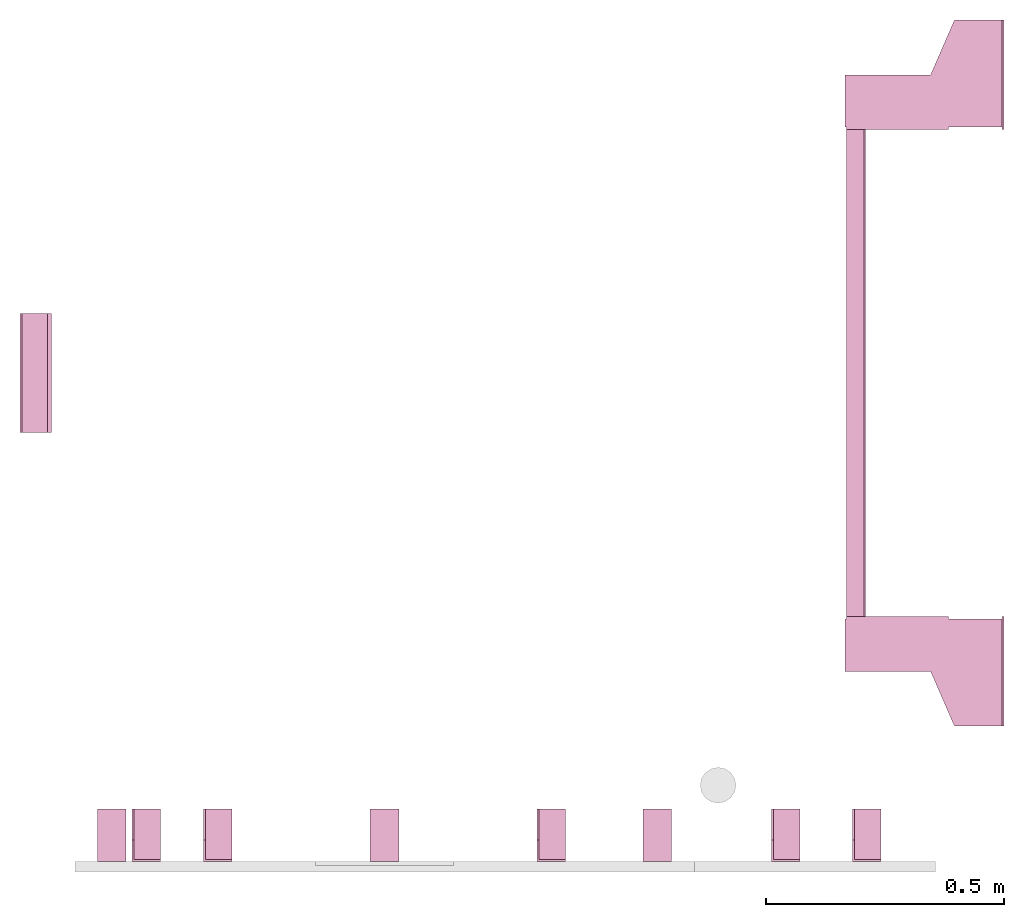
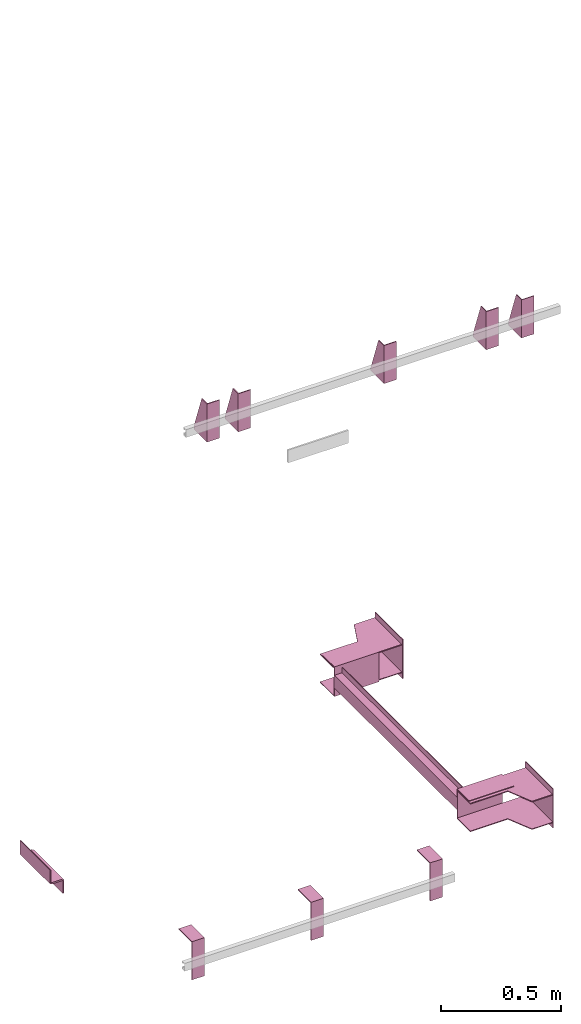
# One storey, part 4 of 4: 10 transport elements.
"""IFC4 building model written with IfcOpenShell, lengths in millimetres."""

from ifc_helpers import new_model, entity, si_unit, converted_unit, frame, origin_with_axes, place, context, subcontext, project, spatial, faceted_brep, element, save


model = new_model("IFC4")

# Units and contexts
context_of_model = context(None, 3, precision=0.01, world=origin_with_axes())
sub_context_1 = subcontext(context_of_model, None, None, "MODEL_VIEW")
sub_context_2 = subcontext(context_of_model, None, None, "MODEL_VIEW")
sub_context_3 = subcontext(context_of_model, None, None, "MODEL_VIEW")
sub_context_4 = subcontext(context_of_model, None, None, "MODEL_VIEW")
sub_context_5 = subcontext(context_of_model, None, None, "MODEL_VIEW")
sub_context_6 = subcontext(context_of_model, None, None, "MODEL_VIEW")
sub_context_7 = subcontext(context_of_model, None, None, "MODEL_VIEW")
sub_context_8 = subcontext(context_of_model, None, None, "MODEL_VIEW")
sub_context_9 = subcontext(context_of_model, None, None, "MODEL_VIEW")
sub_context_10 = subcontext(context_of_model, None, None, "MODEL_VIEW")
ifc_project = project(units=[converted_unit("PLANEANGLEUNIT", "degree", entity("IfcPlaneAngleMeasure", 0.017453292519943), si_unit("PLANEANGLEUNIT", "RADIAN"), dimensions=[0, 0, 0, 0, 0, 0, 0]), si_unit("LENGTHUNIT", "METRE", prefix="MILLI"), si_unit("MASSUNIT", "GRAM", prefix="KILO"), converted_unit("TIMEUNIT", "year", entity("IfcTimeMeasure", 31557600.0), si_unit("TIMEUNIT", "SECOND"), dimensions=[0, 0, 1, 0, 0, 0, 0]), si_unit("THERMODYNAMICTEMPERATUREUNIT", "DEGREE_CELSIUS"), si_unit("AREAUNIT", "SQUARE_METRE"), si_unit("FORCEUNIT", "NEWTON"), si_unit("VOLUMEUNIT", "CUBIC_METRE"), si_unit("PRESSUREUNIT", "PASCAL"), si_unit("SOLIDANGLEUNIT", "STERADIAN")], contexts=[context_of_model])

# Site, building, storey
site = spatial("IfcSite", under=ifc_project)
building = spatial("IfcBuilding", under=site, Name="Document")
placement = place(None, origin_with_axes())
storey_placement = place(placement, frame((0.0, 0.0, -17510.0), z_axis=(0.0, 0.0, 1.0), x_axis=(1.0, 0.0, 0.0)))
storey = spatial("IfcBuildingStorey", under=building, at=storey_placement, Name="P6", Elevation=-17510.0)

# Transport elements
transport_element_1_placement = place(storey_placement, frame((2065.0, 1025.0, -190.0), z_axis=(0.0, 0.0, 1.0), x_axis=(0.0, 1.0, 0.0)))
element("IfcTransportElement", 1, at=transport_element_1_placement, inside=storey, PredefinedType="ELEVATOR", context=sub_context_1, shape_type="Brep", body=[
    faceted_brep([(-611.0, 331.0, -72.5), (-514.0, 331.0, -72.5), (-514.0, 331.0, 72.5), (-611.0, 331.0, 72.5), (-611.0, 331.0, 75.5), (-511.0, 331.0, 75.5), (-511.0, 331.0, -75.5), (-611.0, 331.0, -75.5), (-511.0, 116.0, -75.5), (-511.0, 116.0, 75.5), (-611.0, 116.0, 75.5), (-611.0, 116.0, 72.5), (-514.0, 116.0, 72.5), (-514.0, 116.0, -72.5), (-611.0, 116.0, -72.5), (-611.0, 116.0, -75.5)], [[[0, 1, 2, 3, 4, 5, 6, 7]], [[8, 9, 10, 11, 12, 13, 14, 15]], [[15, 14, 0, 7]], [[13, 12, 2, 1]], [[5, 9, 8, 6]], [[11, 10, 4, 3]], [[6, 8, 15, 7]], [[14, 13, 1, 0]], [[2, 12, 11, 3]], [[10, 9, 5, 4]]]),
    faceted_brep([(-511.0, 291.0, -32.5), (-511.0, 294.0, -32.5), (-511.0, 294.0, -59.5), (-511.0, 291.0, -59.5), (511.0, 291.0, -32.5), (511.0, 291.0, -59.5), (511.0, 294.0, -59.5), (511.0, 294.0, -32.5)], [[[0, 1, 2, 3]], [[4, 5, 6, 7]], [[0, 3, 5, 4]], [[3, 2, 6, 5]], [[2, 1, 7, 6]], [[1, 0, 4, 7]]]),
    faceted_brep([(-511.0, 331.0, 32.5), (511.0, 331.0, 32.5), (511.0, 331.0, -32.5), (-511.0, 331.0, -32.5), (511.0, 328.0, -29.5), (511.0, 328.0, 29.5), (-511.0, 328.0, 29.5), (-511.0, 328.0, -29.5), (511.0, 291.0, -32.5), (511.0, 291.0, -29.5), (-511.0, 291.0, -29.5), (-511.0, 291.0, -32.5), (511.0, 291.0, 29.5), (511.0, 291.0, 32.5), (-511.0, 291.0, 32.5), (-511.0, 291.0, 29.5)], [[[0, 1, 2, 3]], [[4, 5, 6, 7]], [[8, 9, 10, 11]], [[12, 13, 14, 15]], [[11, 10, 7, 6, 15, 14, 0, 3]], [[2, 1, 13, 12, 5, 4, 9, 8]], [[2, 8, 11, 3]], [[10, 9, 4, 7]], [[14, 13, 1, 0]], [[5, 12, 15, 6]]]),
    faceted_brep([(511.0, 331.0, 75.5), (611.0, 331.0, 75.5), (611.0, 331.0, 72.5), (514.0, 331.0, 72.5), (514.0, 331.0, -72.5), (611.0, 331.0, -72.5), (611.0, 331.0, -75.5), (511.0, 331.0, -75.5), (511.0, 116.0, -75.5), (611.0, 116.0, -75.5), (611.0, 116.0, -72.5), (514.0, 116.0, -72.5), (514.0, 116.0, 72.5), (611.0, 116.0, 72.5), (611.0, 116.0, 75.5), (511.0, 116.0, 75.5)], [[[0, 1, 2, 3, 4, 5, 6, 7]], [[8, 9, 10, 11, 12, 13, 14, 15]], [[8, 15, 0, 7]], [[3, 12, 11, 4]], [[5, 10, 9, 6]], [[1, 14, 13, 2]], [[6, 9, 8, 7]], [[11, 10, 5, 4]], [[15, 14, 1, 0]], [[2, 13, 12, 3]]]),
    faceted_brep([(-511.0, 291.0, 59.5), (-511.0, 294.0, 59.5), (-511.0, 294.0, 32.5), (-511.0, 291.0, 32.5), (511.0, 291.0, 59.5), (511.0, 291.0, 32.5), (511.0, 294.0, 32.5), (511.0, 294.0, 59.5)], [[[0, 1, 2, 3]], [[4, 5, 6, 7]], [[0, 3, 5, 4]], [[3, 2, 6, 5]], [[2, 1, 7, 6]], [[1, 0, 4, 7]]]),
    faceted_brep([(516.0, 334.0, -68.5), (626.0, 334.0, -68.5), (626.0, 334.0, -72.5), (516.0, 334.0, -72.5), (741.0, 4.0, -72.5), (741.0, 4.0, -68.5), (516.0, 4.0, -68.5), (516.0, 4.0, -72.5), (626.0, 154.0, -68.5), (741.0, 104.0, -68.5), (741.0, 104.0, -72.5), (626.0, 154.0, -72.5)], [[[0, 1, 2, 3]], [[4, 5, 6, 7]], [[8, 9, 10, 11]], [[7, 6, 0, 3]], [[1, 8, 11, 2]], [[9, 5, 4, 10]], [[2, 11, 10, 4, 7, 3]], [[6, 5, 9, 8, 1, 0]]]),
    faceted_brep([(-626.0, 334.0, 72.5), (-516.0, 334.0, 72.5), (-516.0, 334.0, 68.5), (-626.0, 334.0, 68.5), (-516.0, 4.0, 68.5), (-516.0, 4.0, 72.5), (-741.0, 4.0, 72.5), (-741.0, 4.0, 68.5), (-741.0, 104.0, 72.5), (-626.0, 154.0, 72.5), (-626.0, 154.0, 68.5), (-741.0, 104.0, 68.5)], [[[0, 1, 2, 3]], [[4, 5, 6, 7]], [[8, 9, 10, 11]], [[10, 9, 0, 3]], [[1, 5, 4, 2]], [[7, 6, 8, 11]], [[2, 4, 7, 11, 10, 3]], [[9, 8, 6, 5, 1, 0]]]),
    faceted_brep([(-626.0, 334.0, -68.5), (-516.0, 334.0, -68.5), (-516.0, 334.0, -72.5), (-626.0, 334.0, -72.5), (-516.0, 4.0, -72.5), (-516.0, 4.0, -68.5), (-741.0, 4.0, -68.5), (-741.0, 4.0, -72.5), (-741.0, 104.0, -68.5), (-626.0, 154.0, -68.5), (-626.0, 154.0, -72.5), (-741.0, 104.0, -72.5)], [[[0, 1, 2, 3]], [[4, 5, 6, 7]], [[8, 9, 10, 11]], [[10, 9, 0, 3]], [[1, 5, 4, 2]], [[7, 6, 8, 11]], [[2, 4, 7, 11, 10, 3]], [[9, 8, 6, 5, 1, 0]]]),
    faceted_brep([(516.0, 334.0, 72.5), (626.0, 334.0, 72.5), (626.0, 334.0, 68.5), (516.0, 334.0, 68.5), (741.0, 4.0, 68.5), (741.0, 4.0, 72.5), (516.0, 4.0, 72.5), (516.0, 4.0, 68.5), (626.0, 154.0, 72.5), (741.0, 104.0, 72.5), (741.0, 104.0, 68.5), (626.0, 154.0, 68.5)], [[[0, 1, 2, 3]], [[4, 5, 6, 7]], [[8, 9, 10, 11]], [[7, 6, 0, 3]], [[1, 8, 11, 2]], [[9, 5, 4, 10]], [[2, 11, 10, 4, 7, 3]], [[6, 5, 9, 8, 1, 0]]]),
    faceted_brep([(-511.0, 0.0, -100.0), (-511.0, 0.0, 100.0), (-741.0, 0.0, 100.0), (-741.0, 0.0, -100.0), (-511.0, 4.0, -100.0), (-741.0, 4.0, -100.0), (-741.0, 4.0, 100.0), (-511.0, 4.0, 100.0)], [[[0, 1, 2, 3]], [[4, 5, 6, 7]], [[0, 3, 5, 4]], [[3, 2, 6, 5]], [[2, 1, 7, 6]], [[1, 0, 4, 7]]]),
    faceted_brep([(741.0, 0.0, -100.0), (741.0, 0.0, 100.0), (511.0, 0.0, 100.0), (511.0, 0.0, -100.0), (741.0, 4.0, -100.0), (511.0, 4.0, -100.0), (511.0, 4.0, 100.0), (741.0, 4.0, 100.0)], [[[0, 1, 2, 3]], [[4, 5, 6, 7]], [[0, 3, 5, 4]], [[3, 2, 6, 5]], [[2, 1, 7, 6]], [[1, 0, 4, 7]]]),
])
transport_element_2_placement = place(storey_placement, frame((265.0, 0.0, 2580.0), z_axis=(0.0, 0.0, 1.0), x_axis=(1.0, 0.0, 0.0)))
element("IfcTransportElement", 2, at=transport_element_2_placement, inside=storey, PredefinedType="ELEVATOR", context=sub_context_2, shape_type="Brep", body=[
    faceted_brep([(-30.0, 0.0, -97.0), (-30.0, 0.0, 97.0), (-30.0, 4.0, 97.0), (-30.0, 4.0, -93.0), (-30.0, 110.0, -93.0), (-30.0, 110.0, -97.0), (30.0, 110.0, -97.0), (30.0, 110.0, -93.0), (30.0, 4.0, -93.0), (30.0, 4.0, 97.0), (30.0, 0.0, 97.0), (30.0, 0.0, -97.0)], [[[0, 1, 2, 3, 4, 5]], [[6, 7, 8, 9, 10, 11]], [[11, 10, 1, 0]], [[2, 9, 8, 3]], [[4, 7, 6, 5]], [[5, 6, 11, 0]], [[8, 7, 4, 3]], [[10, 9, 2, 1]]]),
    faceted_brep([(-30.0, 4.0, -93.0), (-30.0, 4.0, 97.0), (-30.0, 45.0, 97.0), (-30.0, 110.0, -82.0), (-30.0, 110.0, -93.0), (-26.0, 4.0, -93.0), (-26.0, 110.0, -93.0), (-26.0, 110.0, -82.0), (-26.0, 45.0, 97.0), (-26.0, 4.0, 97.0)], [[[0, 1, 2, 3, 4]], [[5, 6, 7, 8, 9]], [[5, 0, 4, 6]], [[6, 4, 3, 7]], [[7, 3, 2, 8]], [[8, 2, 1, 9]], [[9, 1, 0, 5]]]),
])
transport_element_3_placement = place(storey_placement, frame((415.0, 0.0, 2580.0), z_axis=(0.0, 0.0, 1.0), x_axis=(1.0, 0.0, 0.0)))
element("IfcTransportElement", 3, at=transport_element_3_placement, inside=storey, PredefinedType="ELEVATOR", context=sub_context_3, shape_type="Brep", body=[
    faceted_brep([(-30.0, 4.0, -93.0), (-30.0, 4.0, 97.0), (-30.0, 45.0, 97.0), (-30.0, 110.0, -82.0), (-30.0, 110.0, -93.0), (-26.0, 4.0, -93.0), (-26.0, 110.0, -93.0), (-26.0, 110.0, -82.0), (-26.0, 45.0, 97.0), (-26.0, 4.0, 97.0)], [[[0, 1, 2, 3, 4]], [[5, 6, 7, 8, 9]], [[5, 0, 4, 6]], [[6, 4, 3, 7]], [[7, 3, 2, 8]], [[8, 2, 1, 9]], [[9, 1, 0, 5]]]),
    faceted_brep([(-30.0, 0.0, -97.0), (-30.0, 0.0, 97.0), (-30.0, 4.0, 97.0), (-30.0, 4.0, -93.0), (-30.0, 110.0, -93.0), (-30.0, 110.0, -97.0), (30.0, 110.0, -97.0), (30.0, 110.0, -93.0), (30.0, 4.0, -93.0), (30.0, 4.0, 97.0), (30.0, 0.0, 97.0), (30.0, 0.0, -97.0)], [[[0, 1, 2, 3, 4, 5]], [[6, 7, 8, 9, 10, 11]], [[11, 10, 1, 0]], [[2, 9, 8, 3]], [[4, 7, 6, 5]], [[5, 6, 11, 0]], [[8, 7, 4, 3]], [[10, 9, 2, 1]]]),
])
transport_element_4_placement = place(storey_placement, frame((1115.0, 0.0, 2580.0), z_axis=(0.0, 0.0, 1.0), x_axis=(1.0, 0.0, 0.0)))
element("IfcTransportElement", 4, at=transport_element_4_placement, inside=storey, PredefinedType="ELEVATOR", context=sub_context_4, shape_type="Brep", body=[
    faceted_brep([(-30.0, 0.0, -97.0), (-30.0, 0.0, 97.0), (-30.0, 4.0, 97.0), (-30.0, 4.0, -93.0), (-30.0, 110.0, -93.0), (-30.0, 110.0, -97.0), (30.0, 110.0, -97.0), (30.0, 110.0, -93.0), (30.0, 4.0, -93.0), (30.0, 4.0, 97.0), (30.0, 0.0, 97.0), (30.0, 0.0, -97.0)], [[[0, 1, 2, 3, 4, 5]], [[6, 7, 8, 9, 10, 11]], [[11, 10, 1, 0]], [[2, 9, 8, 3]], [[4, 7, 6, 5]], [[5, 6, 11, 0]], [[8, 7, 4, 3]], [[10, 9, 2, 1]]]),
    faceted_brep([(-30.0, 4.0, -93.0), (-30.0, 4.0, 97.0), (-30.0, 45.0, 97.0), (-30.0, 110.0, -82.0), (-30.0, 110.0, -93.0), (-26.0, 4.0, -93.0), (-26.0, 110.0, -93.0), (-26.0, 110.0, -82.0), (-26.0, 45.0, 97.0), (-26.0, 4.0, 97.0)], [[[0, 1, 2, 3, 4]], [[5, 6, 7, 8, 9]], [[5, 0, 4, 6]], [[6, 4, 3, 7]], [[7, 3, 2, 8]], [[8, 2, 1, 9]], [[9, 1, 0, 5]]]),
])
transport_element_5_placement = place(storey_placement, frame((1607.0, 0.0, 2580.0), z_axis=(0.0, 0.0, 1.0), x_axis=(1.0, 0.0, 0.0)))
element("IfcTransportElement", 5, at=transport_element_5_placement, inside=storey, PredefinedType="ELEVATOR", context=sub_context_5, shape_type="Brep", body=[
    faceted_brep([(-30.0, 0.0, -97.0), (-30.0, 0.0, 97.0), (-30.0, 4.0, 97.0), (-30.0, 4.0, -93.0), (-30.0, 110.0, -93.0), (-30.0, 110.0, -97.0), (30.0, 110.0, -97.0), (30.0, 110.0, -93.0), (30.0, 4.0, -93.0), (30.0, 4.0, 97.0), (30.0, 0.0, 97.0), (30.0, 0.0, -97.0)], [[[0, 1, 2, 3, 4, 5]], [[6, 7, 8, 9, 10, 11]], [[11, 10, 1, 0]], [[2, 9, 8, 3]], [[4, 7, 6, 5]], [[5, 6, 11, 0]], [[8, 7, 4, 3]], [[10, 9, 2, 1]]]),
    faceted_brep([(-30.0, 4.0, -93.0), (-30.0, 4.0, 97.0), (-30.0, 45.0, 97.0), (-30.0, 110.0, -82.0), (-30.0, 110.0, -93.0), (-26.0, 4.0, -93.0), (-26.0, 110.0, -93.0), (-26.0, 110.0, -82.0), (-26.0, 45.0, 97.0), (-26.0, 4.0, 97.0)], [[[0, 1, 2, 3, 4]], [[5, 6, 7, 8, 9]], [[5, 0, 4, 6]], [[6, 4, 3, 7]], [[7, 3, 2, 8]], [[8, 2, 1, 9]], [[9, 1, 0, 5]]]),
])
transport_element_6_placement = place(storey_placement, frame((1777.0, 0.0, 2580.0), z_axis=(0.0, 0.0, 1.0), x_axis=(1.0, 0.0, 0.0)))
element("IfcTransportElement", 6, at=transport_element_6_placement, inside=storey, PredefinedType="ELEVATOR", context=sub_context_6, shape_type="Brep", body=[
    faceted_brep([(-30.0, 4.0, -93.0), (-30.0, 4.0, 97.0), (-30.0, 45.0, 97.0), (-30.0, 110.0, -82.0), (-30.0, 110.0, -93.0), (-26.0, 4.0, -93.0), (-26.0, 110.0, -93.0), (-26.0, 110.0, -82.0), (-26.0, 45.0, 97.0), (-26.0, 4.0, 97.0)], [[[0, 1, 2, 3, 4]], [[5, 6, 7, 8, 9]], [[5, 0, 4, 6]], [[6, 4, 3, 7]], [[7, 3, 2, 8]], [[8, 2, 1, 9]], [[9, 1, 0, 5]]]),
    faceted_brep([(-30.0, 0.0, -97.0), (-30.0, 0.0, 97.0), (-30.0, 4.0, 97.0), (-30.0, 4.0, -93.0), (-30.0, 110.0, -93.0), (-30.0, 110.0, -97.0), (30.0, 110.0, -97.0), (30.0, 110.0, -93.0), (30.0, 4.0, -93.0), (30.0, 4.0, 97.0), (30.0, 0.0, 97.0), (30.0, 0.0, -97.0)], [[[0, 1, 2, 3, 4, 5]], [[6, 7, 8, 9, 10, 11]], [[11, 10, 1, 0]], [[2, 9, 8, 3]], [[4, 7, 6, 5]], [[5, 6, 11, 0]], [[8, 7, 4, 3]], [[10, 9, 2, 1]]]),
])
transport_element_7_placement = place(storey_placement, frame((1337.5, 0.0, -30.0), z_axis=(0.0, 0.0, -1.0), x_axis=(-1.0, 0.0, 0.0)))
element("IfcTransportElement", 7, at=transport_element_7_placement, inside=storey, PredefinedType="ELEVATOR", context=sub_context_7, shape_type="Brep", body=[
    faceted_brep([(30.0, 0.0, 0.0), (30.0, 110.0, 0.0), (30.0, 110.0, 4.0), (30.0, 4.0, 4.0), (30.0, 4.0, 194.0), (30.0, 0.0, 194.0), (-30.0, 4.0, 194.0), (-30.0, 4.0, 4.0), (-30.0, 110.0, 4.0), (-30.0, 110.0, 0.0), (-30.0, 0.0, 0.0), (-30.0, 0.0, 194.0)], [[[0, 1, 2, 3, 4, 5]], [[6, 7, 8, 9, 10, 11]], [[11, 10, 0, 5]], [[3, 7, 6, 4]], [[1, 9, 8, 2]], [[4, 6, 11, 5]], [[10, 9, 1, 0]], [[2, 8, 7, 3]]]),
    faceted_brep([(-30.0, 4.0, 4.0), (-30.0, 4.0, 194.0), (-30.0, 45.0, 194.0), (-30.0, 110.0, 15.0), (-30.0, 110.0, 4.0), (-26.0, 4.0, 4.0), (-26.0, 110.0, 4.0), (-26.0, 110.0, 15.0), (-26.0, 45.0, 194.0), (-26.0, 4.0, 194.0)], [[[0, 1, 2, 3, 4]], [[5, 6, 7, 8, 9]], [[5, 0, 4, 6]], [[6, 4, 3, 7]], [[7, 3, 2, 8]], [[8, 2, 1, 9]], [[9, 1, 0, 5]]]),
])
transport_element_8_placement = place(storey_placement, frame((765.0, 0.0, -30.0), z_axis=(0.0, 0.0, -1.0), x_axis=(-1.0, 0.0, 0.0)))
element("IfcTransportElement", 8, at=transport_element_8_placement, inside=storey, PredefinedType="ELEVATOR", context=sub_context_8, shape_type="Brep", body=[
    faceted_brep([(30.0, 0.0, 0.0), (30.0, 110.0, 0.0), (30.0, 110.0, 4.0), (30.0, 4.0, 4.0), (30.0, 4.0, 194.0), (30.0, 0.0, 194.0), (-30.0, 4.0, 194.0), (-30.0, 4.0, 4.0), (-30.0, 110.0, 4.0), (-30.0, 110.0, 0.0), (-30.0, 0.0, 0.0), (-30.0, 0.0, 194.0)], [[[0, 1, 2, 3, 4, 5]], [[6, 7, 8, 9, 10, 11]], [[11, 10, 0, 5]], [[3, 7, 6, 4]], [[1, 9, 8, 2]], [[4, 6, 11, 5]], [[10, 9, 1, 0]], [[2, 8, 7, 3]]]),
    faceted_brep([(-30.0, 4.0, 4.0), (-30.0, 4.0, 194.0), (-30.0, 45.0, 194.0), (-30.0, 110.0, 15.0), (-30.0, 110.0, 4.0), (-26.0, 4.0, 4.0), (-26.0, 110.0, 4.0), (-26.0, 110.0, 15.0), (-26.0, 45.0, 194.0), (-26.0, 4.0, 194.0)], [[[0, 1, 2, 3, 4]], [[5, 6, 7, 8, 9]], [[5, 0, 4, 6]], [[6, 4, 3, 7]], [[7, 3, 2, 8]], [[8, 2, 1, 9]], [[9, 1, 0, 5]]]),
])
transport_element_9_placement = place(storey_placement, frame((192.5, 0.0, -30.0), z_axis=(0.0, 0.0, -1.0), x_axis=(-1.0, 0.0, 0.0)))
element("IfcTransportElement", 9, at=transport_element_9_placement, inside=storey, PredefinedType="ELEVATOR", context=sub_context_9, shape_type="Brep", body=[
    faceted_brep([(30.0, 0.0, 0.0), (30.0, 110.0, 0.0), (30.0, 110.0, 4.0), (30.0, 4.0, 4.0), (30.0, 4.0, 194.0), (30.0, 0.0, 194.0), (-30.0, 4.0, 194.0), (-30.0, 4.0, 4.0), (-30.0, 110.0, 4.0), (-30.0, 110.0, 0.0), (-30.0, 0.0, 0.0), (-30.0, 0.0, 194.0)], [[[0, 1, 2, 3, 4, 5]], [[6, 7, 8, 9, 10, 11]], [[11, 10, 0, 5]], [[3, 7, 6, 4]], [[1, 9, 8, 2]], [[4, 6, 11, 5]], [[10, 9, 1, 0]], [[2, 8, 7, 3]]]),
    faceted_brep([(-30.0, 4.0, 4.0), (-30.0, 4.0, 194.0), (-30.0, 45.0, 194.0), (-30.0, 110.0, 15.0), (-30.0, 110.0, 4.0), (-26.0, 4.0, 4.0), (-26.0, 110.0, 4.0), (-26.0, 110.0, 15.0), (-26.0, 45.0, 194.0), (-26.0, 4.0, 194.0)], [[[0, 1, 2, 3, 4]], [[5, 6, 7, 8, 9]], [[5, 0, 4, 6]], [[6, 4, 3, 7]], [[7, 3, 2, 8]], [[8, 2, 1, 9]], [[9, 1, 0, 5]]]),
])
transport_element_10_placement = place(storey_placement, frame((0.0, 1025.0, -190.0), z_axis=(0.0, 0.0, 1.0), x_axis=(0.0, -1.0, 0.0)))
element("IfcTransportElement", 10, at=transport_element_10_placement, inside=storey, PredefinedType="ELEVATOR", context=sub_context_10, shape_type="Brep", body=[
    faceted_brep([(125.0, 0.0, 35.0), (-125.0, 0.0, 35.0), (-125.0, 0.0, -35.0), (125.0, 0.0, -35.0), (-125.0, 4.0, -31.0), (-125.0, 4.0, 35.0), (125.0, 4.0, 35.0), (125.0, 4.0, -31.0), (-125.0, 58.0, -35.0), (-125.0, 58.0, -31.0), (125.0, 58.0, -31.0), (125.0, 58.0, -35.0)], [[[0, 1, 2, 3]], [[4, 5, 6, 7]], [[8, 9, 10, 11]], [[11, 10, 7, 6, 0, 3]], [[2, 1, 5, 4, 9, 8]], [[2, 8, 11, 3]], [[10, 9, 4, 7]], [[6, 5, 1, 0]]]),
    faceted_brep([(125.0, 8.0, -35.0), (-125.0, 8.0, -35.0), (-125.0, 8.0, -39.0), (125.0, 8.0, -39.0), (125.0, 62.0, -39.0), (-125.0, 62.0, -39.0), (-125.0, 62.0, -105.0), (125.0, 62.0, -105.0), (-125.0, 66.0, -105.0), (-125.0, 66.0, -35.0), (125.0, 66.0, -35.0), (125.0, 66.0, -105.0)], [[[0, 1, 2, 3]], [[4, 5, 6, 7]], [[8, 9, 10, 11]], [[4, 7, 11, 10, 0, 3]], [[1, 9, 8, 6, 5, 2]], [[2, 5, 4, 3]], [[10, 9, 1, 0]], [[6, 8, 11, 7]]]),
])

save(model, "model.ifc")
